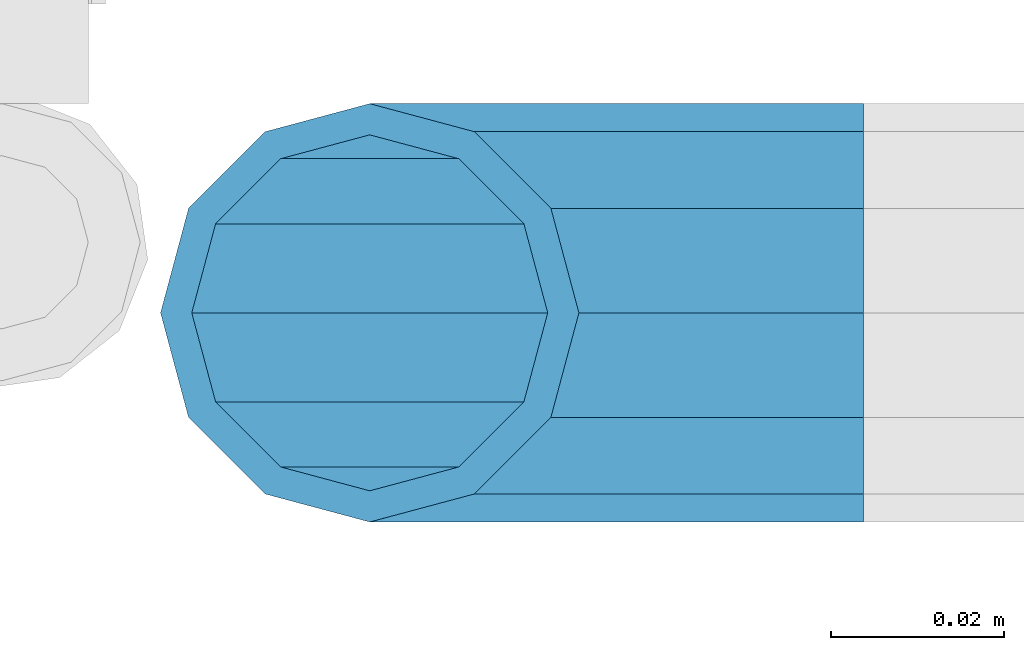
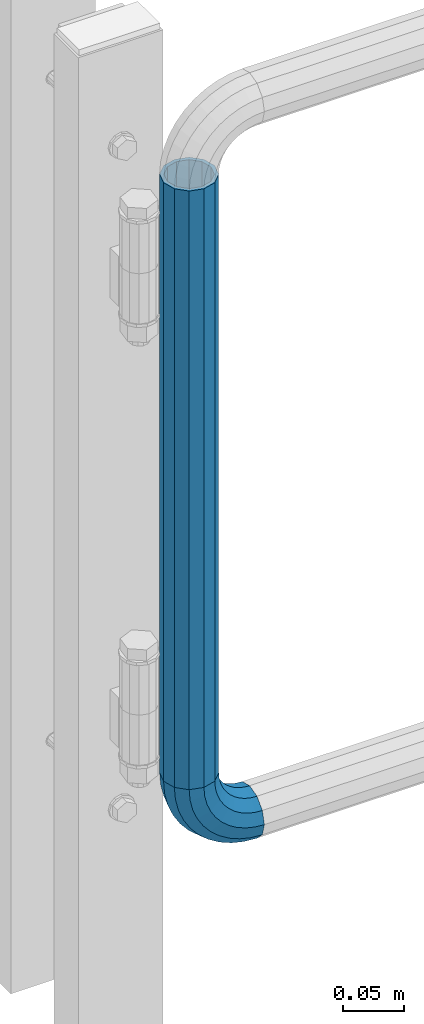
# One storey, part 163 of 247: 1 beam, 1 member.
"""IFC2X3 building model written with IfcOpenShell, lengths in millimetres."""

from ifc_helpers import new_model, si_unit, frame, origin_with_axes, place, context, subcontext, project, spatial, faceted_brep, material, type_object, element, save


model = new_model("IFC2X3")

# Units and contexts
model_context = context("Model", 3, precision=1e-05, world=origin_with_axes())
body_context = subcontext(model_context, "Body", "Model", "MODEL_VIEW")
ifc_project = project(units=[si_unit("LENGTHUNIT", "METRE", prefix="MILLI"), si_unit("AREAUNIT", "SQUARE_METRE"), si_unit("VOLUMEUNIT", "CUBIC_METRE"), si_unit("MASSUNIT", "GRAM", prefix="KILO"), si_unit("TIMEUNIT", "SECOND"), si_unit("PLANEANGLEUNIT", "RADIAN"), si_unit("SOLIDANGLEUNIT", "STERADIAN"), si_unit("THERMODYNAMICTEMPERATUREUNIT", "DEGREE_CELSIUS"), si_unit("LUMINOUSINTENSITYUNIT", "LUMEN")], contexts=[model_context])

# Site, building, storey
site_placement = place(None, origin_with_axes())
site = spatial("IfcSite", under=ifc_project, at=site_placement, CompositionType="ELEMENT")
building_placement = place(site_placement, origin_with_axes())
building = spatial("IfcBuilding", under=site, at=building_placement, Name="Standard", CompositionType="ELEMENT")
storey_placement = place(building_placement, origin_with_axes())
storey = spatial("IfcBuildingStorey", under=building, at=storey_placement, Name="Undefined", CompositionType="ELEMENT", Elevation=0.0)

# Member
ifc_material = material()
member_type = type_object("IfcMemberType", PredefinedType="NOTDEFINED")
member_placement = place(storey_placement, frame((26955.2462613762, 5941.85337247848, 224.650006544463), z_axis=(0.0, -0.999999999999548, -9.5100000000016e-07), x_axis=(-0.707106789186492, 3.85000008583224e-07, 0.707106773186498)))
element("IfcMember", 1, at=member_placement, inside=storey, type_object=member_type, material=ifc_material, context=body_context, shape_type="Brep", body=[
    faceted_brep([(17.0766287656552, -17.0766287656515, 0.0), (14.7887943220521, -14.7887943220485, -12.0749999999998), (19.0945697419556, -11.1113146999705, -12.0749999999998), (20.9963409898264, -13.7288782624128, 0.0), (8.53831438282941, -8.53831438282577, -20.9145135013941), (13.8988340683936, -3.95999805533575, -20.9145135013941), (0.0, 3.63797880709171e-12, -24.1499999999996), (6.80132714696083, 5.80888215174127, -24.1499999999996), (-8.53831438282577, 8.53831438282941, -20.9145135013941), (-0.296179774468328, 15.5777623588219, -20.9145135013941), (-14.7887943220521, 14.7887943220558, -12.0749999999998), (-5.4919154480267, 22.7290790034531, -12.0749999999998), (-17.0766287656552, 17.0766287656588, 0.0), (-7.39368669590112, 25.3466425658989, 0.0), (-14.7887943220521, 14.7887943220558, 12.0749999999998), (-5.4919154480267, 22.7290790034531, 12.0749999999998), (-8.53831438282577, 8.53831438282941, 20.9145135013941), (-0.296179774468328, 15.5777623588219, 20.9145135013941), (0.0, 3.63797880709171e-12, 24.1499999999996), (6.80132714696083, 5.80888215174127, 24.1499999999996), (8.53831438282941, -8.53831438282577, 20.9145135013941), (13.8988340683936, -3.95999805533575, 20.9145135013941), (14.7887943220521, -14.7887943220485, 12.0749999999998), (19.0945697419556, -11.1113146999705, 12.0749999999998), (14.5310443533854, -14.5310443533817, 0.0), (12.5842535535485, -12.5842535535448, 10.2749999999996), (17.2620366843148, -8.58904933077429, 10.2749999999996), (18.8803140815726, -10.8164170826603, 0.0), (7.26552217669087, -7.26552217668723, 17.7968220477705), (12.8408206142667, -2.50376746545953, 17.7968220477705), (0.0, 3.63797880709171e-12, 20.5500000000002), (6.80132714696083, 5.80888215174127, 20.5500000000002), (-7.26552217669087, 7.2655221766945, 17.7968220477705), (0.761833679654956, 14.1215317689421, 17.7968220477705), (-12.5842535535485, 12.5842535535521, 10.2749999999996), (-3.65938239038951, 20.2068136342532, 10.2749999999996), (-14.5310443533817, 14.5310443533854, 0.0), (-5.27765978764728, 22.4341813861465, 0.0), (-12.5842535535485, 12.5842535535521, -10.2749999999996), (-3.65938239038951, 20.2068136342532, -10.2749999999996), (-7.26552217669087, 7.2655221766945, -17.7968220477705), (0.761833679654956, 14.1215317689421, -17.7968220477705), (0.0, 3.63797880709171e-12, -20.5500000000002), (6.80132714696083, 5.80888215174127, -20.5500000000002), (7.26552217669087, -7.26552217668723, -17.7968220477705), (12.8408206142667, -2.50376746545953, -17.7968220477705), (12.5842535535485, -12.5842535535448, -10.2749999999996), (17.2620366843148, -8.58904933077429, -10.2749999999996), (23.922618478784, -8.15268262886457, -12.0749999999998), (25.3914986111849, -11.0355222080434, 0.0), (19.9095633268335, -0.276618428470101, -20.9145135013941), (14.4276280424783, 10.4822853511068, -24.1499999999996), (8.94569275812319, 21.2411891306838, -20.9145135013941), (4.93263760616901, 29.1172533310746, -12.0749999999998), (3.46375747376806, 32.0000929102534, 0.0), (4.93263760616901, 29.1172533310746, 12.0749999999998), (8.94569275812319, 21.2411891306838, 20.9145135013941), (14.4276280424783, 10.4822853511068, 24.1499999999996), (19.9095633268335, -0.276618428470101, 20.9145135013941), (23.922618478784, -8.15268262886457, 12.0749999999998), (22.5072161777207, -5.37479920327678, 10.2749999999996), (23.7571328121303, -7.82789872096328, 0.0), (19.0923804273007, 1.32719331506814, 17.7968220477705), (14.4276280424783, 10.4822853511068, 20.5500000000002), (9.76287565765597, 19.6373773871455, 17.7968220477705), (6.34803990723594, 26.3393699054905, 10.2749999999996), (5.09812327282998, 28.7924694231733, 0.0), (6.34803990723594, 26.3393699054905, -10.2749999999996), (9.76287565765597, 19.6373773871455, -17.7968220477705), (14.4276280424783, 10.4822853511068, -20.5500000000002), (19.0923804273007, 1.32719331506814, -17.7968220477705), (22.5072161777207, -5.37479920327678, -10.2749999999996), (29.1540579492757, -5.98574944944994, -12.0749999999998), (30.1538782624157, -9.0628799673359, 0.0), (26.4224980553372, 2.42112746692874, -20.9145135013941), (22.6911178482587, 13.9051349011934, -24.1499999999996), (18.9597376411839, 25.3891423354544, -20.9145135013941), (16.228177747249, 33.7960192518367, -12.0749999999998), (15.2283574341054, 36.873149769719, 0.0), (16.228177747249, 33.7960192518367, 12.0749999999998), (18.9597376411839, 25.3891423354544, 20.9145135013941), (22.6911178482587, 13.9051349011934, 24.1499999999996), (26.4224980553372, 2.42112746692874, 20.9145135013941), (29.1540579492757, -5.98574944944994, 12.0749999999998), (28.190638306889, -3.02064867668378, 10.2749999999996), (29.0414170826662, -5.63907650866895, 0.0), (25.8662674654624, 4.13302919626221, 17.7968220477705), (22.6911178482587, 13.9051349011934, 20.5500000000002), (19.5159682310587, 23.6772406061282, 17.7968220477705), (17.1915973896357, 30.8309184790705, 10.2749999999996), (16.3408186138549, 33.4493463110593, 0.0), (17.1915973896357, 30.8309184790705, -10.2749999999996), (19.5159682310587, 23.6772406061282, -17.7968220477705), (22.6911178482587, 13.9051349011934, -20.5500000000002), (25.8662674654624, 4.13302919626221, -17.7968220477705), (28.190638306889, -3.02064867668378, -10.2749999999996), (34.660072751507, -4.66387224825303, -12.0749999999998), (35.1662143510621, -7.85952453907885, 0.0), (33.2772681857023, 4.06681217360529, -20.9145135013941), (31.3883220203388, 15.9931488862931, -24.1499999999996), (29.499375854979, 27.9194855989772, -20.9145135013941), (28.1165712891707, 36.6501700208391, -12.0749999999998), (27.6104296896192, 39.8458223116686, 0.0), (28.1165712891707, 36.6501700208391, 12.0749999999998), (29.499375854979, 27.9194855989772, 20.9145135013941), (31.3883220203388, 15.9931488862931, 24.1499999999996), (33.2772681857023, 4.06681217360529, 20.9145135013941), (34.660072751507, -4.66387224825303, 12.0749999999998), (34.1723583567982, -1.58456474993727, 10.2749999999996), (34.6030502769172, -4.30384651293571, 0.0), (32.995686148628, 5.84465118667504, 17.7968220477705), (31.3883220203388, 15.9931488862931, 20.5500000000002), (29.7809578920533, 26.1416465859074, 17.7968220477705), (28.6042856838794, 33.5708625225234, 10.2749999999996), (28.1735937637641, 36.2901442855255, 0.0), (28.6042856838794, 33.5708625225234, -10.2749999999996), (29.7809578920533, 26.1416465859074, -17.7968220477705), (31.3883220203388, 15.9931488862931, -20.5500000000002), (32.995686148628, 5.84465118667504, -17.7968220477705), (34.1723583567982, -1.58456474993727, -10.2749999999996), (40.3050865276309, -4.21960002902415, -12.0749999999998), (40.3050865276346, -7.45508652763237, 0.0), (40.3050865276309, 4.61991347236835, -20.9145135013941), (40.3050865276346, 16.6949134723691, -24.1499999999996), (40.3050865276309, 28.7699134723698, -20.9145135013941), (40.3050865276309, 37.6094269737623, -12.0749999999998), (40.3050865276346, 40.8449134723705, 0.0), (40.3050865276309, 37.6094269737623, 12.0749999999998), (40.3050865276309, 28.7699134723698, 20.9145135013941), (40.3050865276346, 16.6949134723691, 24.1499999999996), (40.3050865276309, 4.61991347236835, 20.9145135013941), (40.3050865276309, -4.21960002902415, 12.0749999999998), (40.3050865276346, -1.10190857540147, 10.2749999999996), (40.3050865276309, -3.85508652763019, 0.0), (40.3050865276346, 6.41991347236763, 17.7968220477705), (40.3050865276346, 16.6949134723691, 20.5500000000002), (40.3050865276346, 26.9699134723705, 17.7968220477705), (40.3050865276346, 34.4917355201396, 10.2749999999996), (40.3050865276309, 37.2449134723684, 0.0), (40.3050865276346, 34.4917355201396, -10.2749999999996), (40.3050865276346, 26.9699134723705, -17.7968220477705), (40.3050865276346, 16.6949134723691, -20.5500000000002), (40.3050865276346, 6.41991347236763, -17.7968220477705), (40.3050865276346, -1.10190857540147, -10.2749999999996), (45.9501003037585, -4.66387224825667, -12.0749999999998), (45.443958704207, -7.85952453907885, 0.0), (47.3329048695668, 4.06681217360529, -20.9145135013941), (49.2218510349267, 15.9931488862894, -24.1499999999996), (51.1107972002865, 27.9194855989808, -20.9145135013941), (52.4936017660912, 36.6501700208391, -12.0749999999998), (52.9997433656463, 39.845822311665, 0.0), (52.4936017660912, 36.6501700208391, 12.0749999999998), (51.1107972002865, 27.9194855989808, 20.9145135013941), (49.2218510349267, 15.9931488862894, 24.1499999999996), (47.3329048695668, 4.06681217360529, 20.9145135013941), (45.9501003037585, -4.66387224825667, 12.0749999999998), (46.4378146984673, -1.58456474993363, 10.2749999999996), (46.0071227783483, -4.30384651293934, 0.0), (47.6144869066338, 5.84465118667504, 17.7968220477705), (49.2218510349267, 15.9931488862894, 20.5500000000002), (50.8292151632122, 26.1416465859038, 17.7968220477705), (52.0058873713861, 33.5708625225197, 10.2749999999996), (52.4365792915014, 36.2901442855218, 0.0), (52.0058873713861, 33.5708625225197, -10.2749999999996), (50.8292151632122, 26.1416465859038, -17.7968220477705), (49.2218510349267, 15.9931488862894, -20.5500000000002), (47.6144869066338, 5.84465118667504, -17.7968220477705), (46.4378146984673, -1.58456474993363, -10.2749999999996), (51.4561151059934, -5.98574944944994, -12.0749999999998), (50.4562947928498, -9.06287996733226, 0.0), (54.1876749999246, 2.42112746692874, -20.9145135013941), (57.9190552070031, 13.9051349011934, -24.1499999999996), (61.6504354140816, 25.389142335458, -20.9145135013941), (64.3819953080201, 33.7960192518367, -12.0749999999998), (65.3818156211564, 36.873149769719, 0.0), (64.3819953080201, 33.7960192518367, 12.0749999999998), (61.6504354140816, 25.389142335458, 20.9145135013941), (57.9190552070031, 13.9051349011934, 24.1499999999996), (54.1876749999246, 2.42112746692874, 20.9145135013941), (51.4561151059934, -5.98574944944994, 12.0749999999998), (52.4195347483801, -3.02064867668378, 10.2749999999996), (51.5687559725993, -5.63907650867259, 0.0), (54.743905589803, 4.13302919625858, 17.7968220477705), (57.9190552070031, 13.9051349011934, 20.5500000000002), (61.0942048242068, 23.6772406061245, 17.7968220477705), (63.4185756656334, 30.8309184790705, 10.2749999999996), (64.2693544414105, 33.4493463110557, 0.0), (63.4185756656334, 30.8309184790705, -10.2749999999996), (61.0942048242068, 23.6772406061245, -17.7968220477705), (57.9190552070031, 13.9051349011934, -20.5500000000002), (54.743905589803, 4.13302919625858, -17.7968220477705), (52.4195347483801, -3.02064867668378, -10.2749999999996), (56.6875545764815, -8.15268262886093, -12.0749999999998), (55.2186744440769, -11.0355222080434, 0.0), (60.700609728432, -0.276618428466463, -20.9145135013941), (66.1825450127908, 10.4822853511068, -24.1499999999996), (71.6644802971423, 21.2411891306801, -20.9145135013941), (75.6775354490928, 29.1172533310746, -12.0749999999998), (77.1464155814938, 32.0000929102534, 0.0), (75.6775354490928, 29.1172533310746, 12.0749999999998), (71.6644802971423, 21.2411891306801, 20.9145135013941), (66.1825450127908, 10.4822853511068, 24.1499999999996), (60.700609728432, -0.276618428466463, 20.9145135013941), (56.6875545764815, -8.15268262886093, 12.0749999999998), (58.1029568775448, -5.37479920327314, 10.2749999999996), (56.8530402431388, -7.82789872096328, 0.0), (61.5177926279612, 1.32719331506814, 17.7968220477705), (66.1825450127908, 10.4822853511068, 20.5500000000002), (70.8472973976095, 19.6373773871419, 17.7968220477705), (74.2621331480295, 26.3393699054868, 10.2749999999996), (75.5120497824355, 28.792469423177, 0.0), (74.2621331480295, 26.3393699054868, -10.2749999999996), (70.8472973976095, 19.6373773871419, -17.7968220477705), (66.1825450127908, 10.4822853511068, -20.5500000000002), (61.5177926279612, 1.32719331506814, -17.7968220477705), (58.1029568775448, -5.37479920327314, -10.2749999999996), (61.5156033133135, -11.1113146999705, -12.0749999999998), (59.6138320654427, -13.7288782624128, 0.0), (66.7113389868719, -3.95999805533938, -20.9145135013941), (73.8088459083046, 5.80888215174491, -24.1499999999996), (80.9063528297338, 15.5777623588183, -20.9145135013941), (86.1020885032958, 22.7290790034531, -12.0749999999998), (88.0038597511666, 25.3466425658953, 0.0), (86.1020885032958, 22.7290790034531, 12.0749999999998), (80.9063528297338, 15.5777623588183, 20.9145135013941), (73.8088459083046, 5.80888215174491, 24.1499999999996), (66.7113389868719, -3.95999805533938, 20.9145135013941), (61.5156033133135, -11.1113146999705, 12.0749999999998), (63.3481363709507, -8.58904933077065, 10.2749999999996), (61.7298589736929, -10.816417082664, 0.0), (67.7693524410024, -2.50376746545953, 17.7968220477705), (73.8088459083046, 5.80888215174491, 20.5500000000002), (79.8483393756105, 14.1215317689457, 17.7968220477705), (84.2695554456586, 20.2068136342532, 10.2749999999996), (85.8878328429164, 22.4341813861465, 0.0), (84.2695554456586, 20.2068136342532, -10.2749999999996), (79.8483393756105, 14.1215317689457, -17.7968220477705), (73.8088459083046, 5.80888215174491, -20.5500000000002), (67.7693524410024, -2.50376746545953, -17.7968220477705), (63.3481363709507, -8.58904933077065, -10.2749999999996), (65.8213787332134, -14.7887943220521, -12.0749999999998), (63.5335442896103, -17.0766287656552, 0.0), (72.0718586724397, -8.53831438282577, -20.9145135013941), (80.6101730552655, 0.0, -24.1499999999996), (89.1484874380949, 8.53831438282941, -20.9145135013941), (95.3989673773212, 14.7887943220558, -12.0749999999998), (97.6868018209243, 17.0766287656588, 0.0), (95.3989673773212, 14.7887943220558, 12.0749999999998), (89.1484874380949, 8.53831438282941, 20.9145135013941), (80.6101730552655, 0.0, 24.1499999999996), (72.0718586724397, -8.53831438282577, 20.9145135013941), (65.8213787332134, -14.7887943220521, 12.0749999999998), (68.025919501717, -12.5842535535485, 10.2749999999996), (66.0791287018837, -14.5310443533817, 0.0), (73.3446508785746, -7.26552217669087, 17.7968220477705), (80.6101730552655, 0.0, 20.5500000000002), (87.87569523196, 7.2655221766945, 17.7968220477705), (93.1944266088176, 12.5842535535521, 10.2749999999996), (95.1412174086508, 14.5310443533854, 0.0), (93.1944266088176, 12.5842535535521, -10.2749999999996), (87.87569523196, 7.2655221766945, -17.7968220477705), (80.6101730552655, 0.0, -20.5500000000002), (73.3446508785746, -7.26552217669087, -17.7968220477705), (68.025919501717, -12.5842535535485, -10.2749999999996)], [[[0, 1, 2, 3]], [[1, 4, 5, 2]], [[4, 6, 7, 5]], [[6, 8, 9, 7]], [[8, 10, 11, 9]], [[10, 12, 13, 11]], [[12, 14, 15, 13]], [[14, 16, 17, 15]], [[16, 18, 19, 17]], [[18, 20, 21, 19]], [[20, 22, 23, 21]], [[22, 0, 3, 23]], [[24, 25, 26, 27]], [[25, 28, 29, 26]], [[28, 30, 31, 29]], [[30, 32, 33, 31]], [[32, 34, 35, 33]], [[34, 36, 37, 35]], [[36, 38, 39, 37]], [[38, 40, 41, 39]], [[40, 42, 43, 41]], [[42, 44, 45, 43]], [[44, 46, 47, 45]], [[46, 24, 27, 47]], [[22, 20, 18, 16, 14, 12, 10, 8, 6, 4, 1, 0], [46, 44, 42, 40, 38, 36, 34, 32, 30, 28, 25, 24]], [[3, 2, 48, 49]], [[2, 5, 50, 48]], [[5, 7, 51, 50]], [[7, 9, 52, 51]], [[9, 11, 53, 52]], [[11, 13, 54, 53]], [[13, 15, 55, 54]], [[15, 17, 56, 55]], [[17, 19, 57, 56]], [[19, 21, 58, 57]], [[21, 23, 59, 58]], [[23, 3, 49, 59]], [[27, 26, 60, 61]], [[26, 29, 62, 60]], [[29, 31, 63, 62]], [[31, 33, 64, 63]], [[33, 35, 65, 64]], [[35, 37, 66, 65]], [[37, 39, 67, 66]], [[39, 41, 68, 67]], [[41, 43, 69, 68]], [[43, 45, 70, 69]], [[45, 47, 71, 70]], [[47, 27, 61, 71]], [[49, 48, 72, 73]], [[48, 50, 74, 72]], [[50, 51, 75, 74]], [[51, 52, 76, 75]], [[52, 53, 77, 76]], [[53, 54, 78, 77]], [[54, 55, 79, 78]], [[55, 56, 80, 79]], [[56, 57, 81, 80]], [[57, 58, 82, 81]], [[58, 59, 83, 82]], [[59, 49, 73, 83]], [[61, 60, 84, 85]], [[60, 62, 86, 84]], [[62, 63, 87, 86]], [[63, 64, 88, 87]], [[64, 65, 89, 88]], [[65, 66, 90, 89]], [[66, 67, 91, 90]], [[67, 68, 92, 91]], [[68, 69, 93, 92]], [[69, 70, 94, 93]], [[70, 71, 95, 94]], [[71, 61, 85, 95]], [[73, 72, 96, 97]], [[72, 74, 98, 96]], [[74, 75, 99, 98]], [[75, 76, 100, 99]], [[76, 77, 101, 100]], [[77, 78, 102, 101]], [[78, 79, 103, 102]], [[79, 80, 104, 103]], [[80, 81, 105, 104]], [[81, 82, 106, 105]], [[82, 83, 107, 106]], [[83, 73, 97, 107]], [[85, 84, 108, 109]], [[84, 86, 110, 108]], [[86, 87, 111, 110]], [[87, 88, 112, 111]], [[88, 89, 113, 112]], [[89, 90, 114, 113]], [[90, 91, 115, 114]], [[91, 92, 116, 115]], [[92, 93, 117, 116]], [[93, 94, 118, 117]], [[94, 95, 119, 118]], [[95, 85, 109, 119]], [[97, 96, 120, 121]], [[96, 98, 122, 120]], [[98, 99, 123, 122]], [[99, 100, 124, 123]], [[100, 101, 125, 124]], [[101, 102, 126, 125]], [[102, 103, 127, 126]], [[103, 104, 128, 127]], [[104, 105, 129, 128]], [[105, 106, 130, 129]], [[106, 107, 131, 130]], [[107, 97, 121, 131]], [[109, 108, 132, 133]], [[108, 110, 134, 132]], [[110, 111, 135, 134]], [[111, 112, 136, 135]], [[112, 113, 137, 136]], [[113, 114, 138, 137]], [[114, 115, 139, 138]], [[115, 116, 140, 139]], [[116, 117, 141, 140]], [[117, 118, 142, 141]], [[118, 119, 143, 142]], [[119, 109, 133, 143]], [[121, 120, 144, 145]], [[120, 122, 146, 144]], [[122, 123, 147, 146]], [[123, 124, 148, 147]], [[124, 125, 149, 148]], [[125, 126, 150, 149]], [[126, 127, 151, 150]], [[127, 128, 152, 151]], [[128, 129, 153, 152]], [[129, 130, 154, 153]], [[130, 131, 155, 154]], [[131, 121, 145, 155]], [[133, 132, 156, 157]], [[132, 134, 158, 156]], [[134, 135, 159, 158]], [[135, 136, 160, 159]], [[136, 137, 161, 160]], [[137, 138, 162, 161]], [[138, 139, 163, 162]], [[139, 140, 164, 163]], [[140, 141, 165, 164]], [[141, 142, 166, 165]], [[142, 143, 167, 166]], [[143, 133, 157, 167]], [[145, 144, 168, 169]], [[144, 146, 170, 168]], [[146, 147, 171, 170]], [[147, 148, 172, 171]], [[148, 149, 173, 172]], [[149, 150, 174, 173]], [[150, 151, 175, 174]], [[151, 152, 176, 175]], [[152, 153, 177, 176]], [[153, 154, 178, 177]], [[154, 155, 179, 178]], [[155, 145, 169, 179]], [[157, 156, 180, 181]], [[156, 158, 182, 180]], [[158, 159, 183, 182]], [[159, 160, 184, 183]], [[160, 161, 185, 184]], [[161, 162, 186, 185]], [[162, 163, 187, 186]], [[163, 164, 188, 187]], [[164, 165, 189, 188]], [[165, 166, 190, 189]], [[166, 167, 191, 190]], [[167, 157, 181, 191]], [[169, 168, 192, 193]], [[168, 170, 194, 192]], [[170, 171, 195, 194]], [[171, 172, 196, 195]], [[172, 173, 197, 196]], [[173, 174, 198, 197]], [[174, 175, 199, 198]], [[175, 176, 200, 199]], [[176, 177, 201, 200]], [[177, 178, 202, 201]], [[178, 179, 203, 202]], [[179, 169, 193, 203]], [[181, 180, 204, 205]], [[180, 182, 206, 204]], [[182, 183, 207, 206]], [[183, 184, 208, 207]], [[184, 185, 209, 208]], [[185, 186, 210, 209]], [[186, 187, 211, 210]], [[187, 188, 212, 211]], [[188, 189, 213, 212]], [[189, 190, 214, 213]], [[190, 191, 215, 214]], [[191, 181, 205, 215]], [[193, 192, 216, 217]], [[192, 194, 218, 216]], [[194, 195, 219, 218]], [[195, 196, 220, 219]], [[196, 197, 221, 220]], [[197, 198, 222, 221]], [[198, 199, 223, 222]], [[199, 200, 224, 223]], [[200, 201, 225, 224]], [[201, 202, 226, 225]], [[202, 203, 227, 226]], [[203, 193, 217, 227]], [[205, 204, 228, 229]], [[204, 206, 230, 228]], [[206, 207, 231, 230]], [[207, 208, 232, 231]], [[208, 209, 233, 232]], [[209, 210, 234, 233]], [[210, 211, 235, 234]], [[211, 212, 236, 235]], [[212, 213, 237, 236]], [[213, 214, 238, 237]], [[214, 215, 239, 238]], [[215, 205, 229, 239]], [[217, 216, 240, 241]], [[216, 218, 242, 240]], [[218, 219, 243, 242]], [[219, 220, 244, 243]], [[220, 221, 245, 244]], [[221, 222, 246, 245]], [[222, 223, 247, 246]], [[223, 224, 248, 247]], [[224, 225, 249, 248]], [[225, 226, 250, 249]], [[226, 227, 251, 250]], [[227, 217, 241, 251]], [[229, 228, 252, 253]], [[228, 230, 254, 252]], [[230, 231, 255, 254]], [[231, 232, 256, 255]], [[232, 233, 257, 256]], [[233, 234, 258, 257]], [[234, 235, 259, 258]], [[235, 236, 260, 259]], [[236, 237, 261, 260]], [[237, 238, 262, 261]], [[238, 239, 263, 262]], [[239, 229, 253, 263]], [[242, 243, 244, 245, 246, 247, 248, 249, 250, 251, 241, 240], [254, 255, 256, 257, 258, 259, 260, 261, 262, 263, 253, 252]]]),
])

# Beam
beam_type = type_object("IfcBeamType", PredefinedType="NOTDEFINED")
beam_placement = place(storey_placement, frame((26898.2462613762, 5941.85337247848, 878.350006544462), z_axis=(1.0, 0.0, 0.0), x_axis=(0.0, 0.0, -1.0)))
element("IfcBeam", 2, at=beam_placement, inside=storey, type_object=beam_type, material=ifc_material, context=body_context, shape_type="Brep", body=[
    faceted_brep([(0.0, -20.5500000000002, 0.0), (0.0, -17.7968220477705, 10.2750000000015), (596.700000000001, -17.7968220477705, 10.2750000000015), (596.700000000001, -20.5500000000002, 0.0), (0.0, -10.2749999999996, 17.7968220477705), (596.700000000001, -10.2749999999996, 17.7968220477705), (0.0, 3.63797880709171e-12, 20.5500000000002), (596.700000000001, 0.0, 20.5499999999993), (0.0, 10.2749999999996, 17.7968220477705), (596.700000000001, 10.2749999999996, 17.7968220477705), (0.0, 17.7968220477705, 10.2750000000015), (596.700000000001, 17.7968220477705, 10.2750000000015), (0.0, 20.5500000000002, 0.0), (596.700000000001, 20.5500000000002, 0.0), (0.0, 17.7968220477705, -10.2750000000015), (596.700000000001, 17.7968220477705, -10.2750000000015), (0.0, 10.2749999999996, -17.7968220477705), (596.700000000001, 10.2749999999996, -17.7968220477705), (0.0, 3.63797880709171e-12, -20.5500000000002), (596.700000000001, 0.0, -20.5499999999993), (0.0, -10.2749999999996, -17.7968220477705), (596.700000000001, -10.2749999999996, -17.7968220477705), (0.0, -17.7968220477705, -10.2750000000015), (596.700000000001, -17.7968220477705, -10.2750000000015), (0.0, -24.1499999999996, 0.0), (0.0, -20.9145135013941, -12.0750000000007), (596.700000000001, -20.9145135013941, -12.0750000000007), (596.700000000001, -24.1499999999996, 0.0), (0.0, -12.0749999999998, -20.9145135013932), (596.700000000001, -12.0749999999998, -20.9145135013932), (0.0, 3.63797880709171e-12, -24.1499999999996), (596.700000000001, 0.0, -24.1500000000015), (0.0, 12.0749999999998, -20.9145135013932), (596.700000000001, 12.0749999999998, -20.9145135013932), (0.0, 20.9145135013941, -12.0750000000007), (596.700000000001, 20.9145135013941, -12.0750000000007), (0.0, 24.1499999999996, 0.0), (596.700000000001, 24.1499999999996, 0.0), (0.0, 20.9145135013941, 12.0750000000007), (596.700000000001, 20.9145135013941, 12.0750000000007), (0.0, 12.0749999999998, 20.9145135013932), (596.700000000001, 12.0749999999998, 20.9145135013932), (0.0, 3.63797880709171e-12, 24.1499999999996), (596.700000000001, 0.0, 24.1500000000015), (0.0, -12.0749999999998, 20.9145135013932), (596.700000000001, -12.0749999999998, 20.9145135013932), (0.0, -20.9145135013941, 12.0750000000007), (596.700000000001, -20.9145135013941, 12.0750000000007)], [[[0, 1, 2, 3]], [[1, 4, 5, 2]], [[4, 6, 7, 5]], [[6, 8, 9, 7]], [[8, 10, 11, 9]], [[10, 12, 13, 11]], [[12, 14, 15, 13]], [[14, 16, 17, 15]], [[16, 18, 19, 17]], [[18, 20, 21, 19]], [[20, 22, 23, 21]], [[22, 0, 3, 23]], [[24, 25, 26, 27]], [[25, 28, 29, 26]], [[28, 30, 31, 29]], [[30, 32, 33, 31]], [[32, 34, 35, 33]], [[34, 36, 37, 35]], [[36, 38, 39, 37]], [[38, 40, 41, 39]], [[40, 42, 43, 41]], [[42, 44, 45, 43]], [[44, 46, 47, 45]], [[46, 24, 27, 47]], [[29, 31, 33, 35, 37, 39, 41, 43, 45, 47, 27, 26], [5, 7, 9, 11, 13, 15, 17, 19, 21, 23, 3, 2]], [[46, 44, 42, 40, 38, 36, 34, 32, 30, 28, 25, 24], [22, 20, 18, 16, 14, 12, 10, 8, 6, 4, 1, 0]]]),
])

save(model, "model.ifc")
